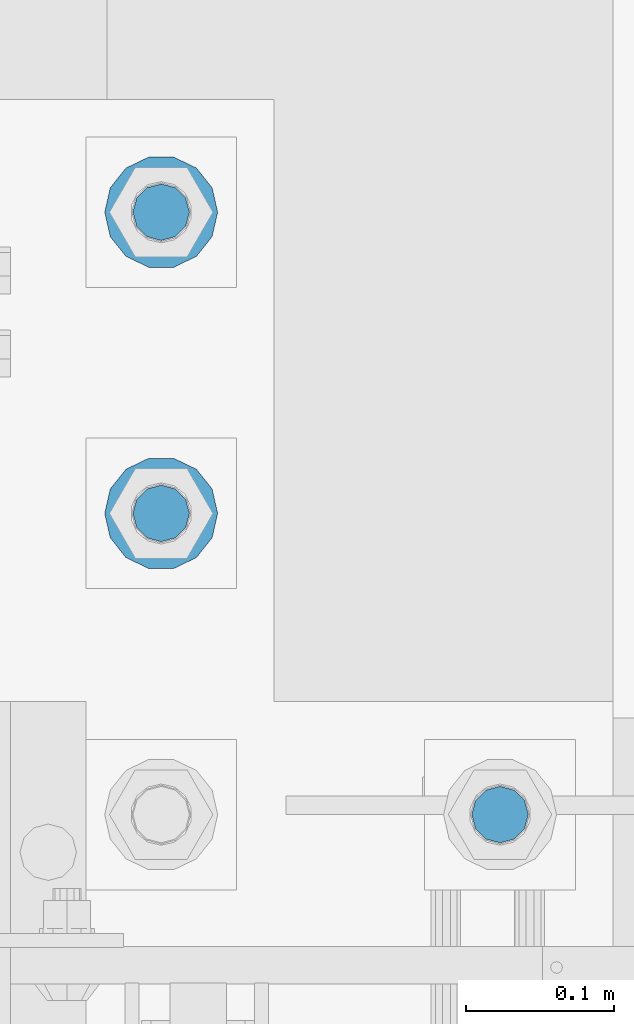
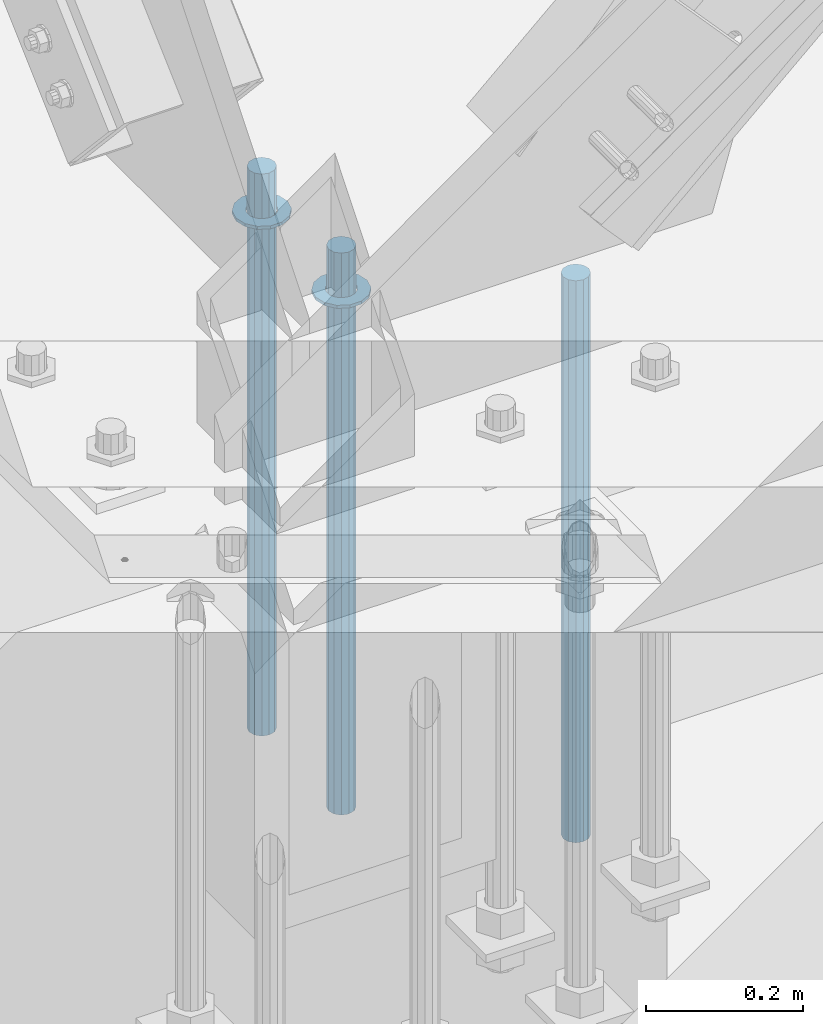
# One storey, part 920 of 1763: 5 columns, 1 element without a shape of its own.
"""IFC2X3 building model written with IfcOpenShell, lengths in millimetres."""

from ifc_helpers import new_model, si_unit, frame, origin_with_axes, place, context, subcontext, project, spatial, faceted_brep, material, type_object, element, aggregate, save


model = new_model("IFC2X3")

# Units and contexts
model_context = context("Model", 3, precision=1e-05, world=origin_with_axes())
body_context = subcontext(model_context, "Body", "Model", "MODEL_VIEW")
ifc_project = project(units=[si_unit("LENGTHUNIT", "METRE", prefix="MILLI"), si_unit("AREAUNIT", "SQUARE_METRE"), si_unit("VOLUMEUNIT", "CUBIC_METRE"), si_unit("MASSUNIT", "GRAM", prefix="KILO"), si_unit("TIMEUNIT", "SECOND"), si_unit("PLANEANGLEUNIT", "RADIAN"), si_unit("SOLIDANGLEUNIT", "STERADIAN"), si_unit("THERMODYNAMICTEMPERATUREUNIT", "DEGREE_CELSIUS"), si_unit("LUMINOUSINTENSITYUNIT", "LUMEN")], contexts=[model_context])

# Site, building, storey
site_placement = place(None, origin_with_axes())
site = spatial("IfcSite", under=ifc_project, at=site_placement, CompositionType="ELEMENT")
building_placement = place(site_placement, origin_with_axes())
building = spatial("IfcBuilding", under=site, at=building_placement, Name="Undefined", CompositionType="ELEMENT")
storey_placement = place(building_placement, origin_with_axes())
storey = spatial("IfcBuildingStorey", under=building, at=storey_placement, Name="Undefined", CompositionType="ELEMENT", Elevation=0.0)

# Assembly, columns
assembly_placement = place(storey_placement, origin_with_axes())
assembly = element("IfcElementAssembly", 1, at=assembly_placement, inside=storey, Name="TEMPLATE", AssemblyPlace="NOTDEFINED", PredefinedType="RIGID_FRAME")
ifc_material_1 = material(Name="STEEL/F436")
column_type_1 = type_object("IfcColumnType", Name="1-1/2_WASHER", PredefinedType="NOTDEFINED")
column_1_placement = place(assembly_placement, frame((-87146.8372736983, -13411.2, 5151.43750000001), z_axis=(0.0, 1.0, 0.0), x_axis=(0.0, 0.0, -1.0)))
column_1 = element("IfcColumn", 2, at=column_1_placement, type_object=column_type_1, material=ifc_material_1, Name="WASHER", ObjectType="1-1/2_WASHER", context=body_context, shape_type="Brep", body=[
    faceted_brep([(0.0, -38.0999984741211, 0.0), (0.0, -34.3269124923099, -16.5309697983248), (4.76249999999982, -34.3269124923099, -16.5309697983248), (4.76249999999982, -38.0999984741211, 0.0), (0.0, -23.7549604994492, -29.7877782890519), (4.76249999999982, -23.7549604994492, -29.7877782890519), (0.0, -8.47804724419257, -37.1447519665053), (4.76249999999982, -8.47804724419257, -37.1447519665053), (0.0, 8.47804724419257, -37.1447519665053), (4.76249999999982, 8.47804724419257, -37.1447519665053), (0.0, 23.7549604994492, -29.7877782890519), (4.76249999999982, 23.7549604994492, -29.7877782890519), (0.0, 34.3269124923099, -16.5309697983248), (4.76249999999982, 34.3269124923099, -16.5309697983248), (0.0, 38.0999984741211, 0.0), (4.76249999999982, 38.0999984741211, 0.0), (0.0, 34.3269124923099, 16.5309697983248), (4.76249999999982, 34.3269124923099, 16.5309697983248), (0.0, 23.7549604994492, 29.7877782890519), (4.76249999999982, 23.7549604994492, 29.7877782890519), (0.0, 8.47804724419257, 37.1447519665053), (4.76249999999982, 8.47804724419257, 37.1447519665053), (0.0, -8.47804724419257, 37.1447519665053), (4.76249999999982, -8.47804724419257, 37.1447519665053), (0.0, -23.7549604994492, 29.7877782890519), (4.76249999999982, -23.7549604994492, 29.7877782890519), (0.0, -34.3269124923099, 16.5309697983248), (4.76249999999982, -34.3269124923099, 16.5309697983248), (0.0, 0.0, 20.6399993896484), (0.0, 8.95536011056538, 18.5959968835978), (4.76249999999982, 8.95536011056538, 18.5959968835978), (4.76249999999982, 0.0, 20.6399993896484), (0.0, 16.1370013209453, 12.8688291298167), (4.76249999999982, 16.1370013209453, 12.8688291298167), (0.0, 20.1225115123816, 4.59283194104137), (4.76249999999982, 20.1225115123816, 4.59283194104137), (0.0, 20.1225115123816, -4.59283194104319), (4.76249999999982, 20.1225115123816, -4.59283194104319), (0.0, 16.1370013209453, -12.8688291298167), (4.76249999999982, 16.1370013209453, -12.8688291298167), (0.0, 8.95536011056538, -18.5959968835978), (4.76249999999982, 8.95536011056538, -18.5959968835978), (0.0, 0.0, -20.6399993896484), (4.76249999999982, 0.0, -20.6399993896484), (0.0, -8.95536011056538, -18.5959968835978), (4.76249999999982, -8.95536011056538, -18.5959968835978), (0.0, -16.1370013209453, -12.8688291298167), (4.76249999999982, -16.1370013209453, -12.8688291298167), (0.0, -20.1225115123816, -4.59283194104137), (4.76249999999982, -20.1225115123816, -4.59283194104137), (0.0, -20.1225115123816, 4.59283194104319), (4.76249999999982, -20.1225115123816, 4.59283194104319), (0.0, -16.1370013209453, 12.8688291298167), (4.76249999999982, -16.1370013209453, 12.8688291298167), (0.0, -8.95536011056538, 18.5959968835978), (4.76249999999982, -8.95536011056538, 18.5959968835978)], [[[0, 1, 2, 3]], [[1, 4, 5, 2]], [[4, 6, 7, 5]], [[6, 8, 9, 7]], [[8, 10, 11, 9]], [[10, 12, 13, 11]], [[12, 14, 15, 13]], [[14, 16, 17, 15]], [[16, 18, 19, 17]], [[18, 20, 21, 19]], [[20, 22, 23, 21]], [[22, 24, 25, 23]], [[24, 26, 27, 25]], [[26, 0, 3, 27]], [[28, 29, 30, 31]], [[29, 32, 33, 30]], [[32, 34, 35, 33]], [[34, 36, 37, 35]], [[36, 38, 39, 37]], [[38, 40, 41, 39]], [[40, 42, 43, 41]], [[42, 44, 45, 43]], [[44, 46, 47, 45]], [[46, 48, 49, 47]], [[48, 50, 51, 49]], [[50, 52, 53, 51]], [[52, 54, 55, 53]], [[54, 28, 31, 55]], [[5, 7, 9, 11, 13, 15, 17, 19, 21, 23, 25, 27, 3, 2], [33, 35, 37, 39, 41, 43, 45, 47, 49, 51, 53, 55, 31, 30]], [[26, 24, 22, 20, 18, 16, 14, 12, 10, 8, 6, 4, 1, 0], [54, 52, 50, 48, 46, 44, 42, 40, 38, 36, 34, 32, 29, 28]]]),
])
column_2_placement = place(assembly_placement, frame((-87146.8372736983, -13208.0, 5151.43750000001), z_axis=(0.0, 1.0, 0.0), x_axis=(0.0, 0.0, -1.0)))
column_2 = element("IfcColumn", 3, at=column_2_placement, type_object=column_type_1, material=ifc_material_1, Name="WASHER", ObjectType="1-1/2_WASHER", context=body_context, shape_type="Brep", body=[
    faceted_brep([(0.0, -38.0999984741211, 0.0), (0.0, -34.3269124923099, -16.5309697983248), (4.76249999999982, -34.3269124923099, -16.5309697983248), (4.76249999999982, -38.0999984741211, 0.0), (0.0, -23.7549604994492, -29.7877782890519), (4.76249999999982, -23.7549604994492, -29.7877782890519), (0.0, -8.47804724419257, -37.1447519665053), (4.76249999999982, -8.47804724419257, -37.1447519665053), (0.0, 8.47804724419257, -37.1447519665053), (4.76249999999982, 8.47804724419257, -37.1447519665053), (0.0, 23.7549604994492, -29.7877782890519), (4.76249999999982, 23.7549604994492, -29.7877782890519), (0.0, 34.3269124923099, -16.5309697983248), (4.76249999999982, 34.3269124923099, -16.5309697983248), (0.0, 38.0999984741211, 0.0), (4.76249999999982, 38.0999984741211, 0.0), (0.0, 34.3269124923099, 16.5309697983248), (4.76249999999982, 34.3269124923099, 16.5309697983248), (0.0, 23.7549604994492, 29.7877782890519), (4.76249999999982, 23.7549604994492, 29.7877782890519), (0.0, 8.47804724419257, 37.1447519665053), (4.76249999999982, 8.47804724419257, 37.1447519665053), (0.0, -8.47804724419257, 37.1447519665053), (4.76249999999982, -8.47804724419257, 37.1447519665053), (0.0, -23.7549604994492, 29.7877782890519), (4.76249999999982, -23.7549604994492, 29.7877782890519), (0.0, -34.3269124923099, 16.5309697983248), (4.76249999999982, -34.3269124923099, 16.5309697983248), (0.0, 0.0, 20.6399993896484), (0.0, 8.95536011056538, 18.5959968835978), (4.76249999999982, 8.95536011056538, 18.5959968835978), (4.76249999999982, 0.0, 20.6399993896484), (0.0, 16.1370013209453, 12.8688291298167), (4.76249999999982, 16.1370013209453, 12.8688291298167), (0.0, 20.1225115123816, 4.59283194104137), (4.76249999999982, 20.1225115123816, 4.59283194104137), (0.0, 20.1225115123816, -4.59283194104319), (4.76249999999982, 20.1225115123816, -4.59283194104319), (0.0, 16.1370013209453, -12.8688291298167), (4.76249999999982, 16.1370013209453, -12.8688291298167), (0.0, 8.95536011056538, -18.5959968835978), (4.76249999999982, 8.95536011056538, -18.5959968835978), (0.0, 0.0, -20.6399993896484), (4.76249999999982, 0.0, -20.6399993896484), (0.0, -8.95536011056538, -18.5959968835978), (4.76249999999982, -8.95536011056538, -18.5959968835978), (0.0, -16.1370013209453, -12.8688291298167), (4.76249999999982, -16.1370013209453, -12.8688291298167), (0.0, -20.1225115123816, -4.59283194104137), (4.76249999999982, -20.1225115123816, -4.59283194104137), (0.0, -20.1225115123816, 4.59283194104319), (4.76249999999982, -20.1225115123816, 4.59283194104319), (0.0, -16.1370013209453, 12.8688291298167), (4.76249999999982, -16.1370013209453, 12.8688291298167), (0.0, -8.95536011056538, 18.5959968835978), (4.76249999999982, -8.95536011056538, 18.5959968835978)], [[[0, 1, 2, 3]], [[1, 4, 5, 2]], [[4, 6, 7, 5]], [[6, 8, 9, 7]], [[8, 10, 11, 9]], [[10, 12, 13, 11]], [[12, 14, 15, 13]], [[14, 16, 17, 15]], [[16, 18, 19, 17]], [[18, 20, 21, 19]], [[20, 22, 23, 21]], [[22, 24, 25, 23]], [[24, 26, 27, 25]], [[26, 0, 3, 27]], [[28, 29, 30, 31]], [[29, 32, 33, 30]], [[32, 34, 35, 33]], [[34, 36, 37, 35]], [[36, 38, 39, 37]], [[38, 40, 41, 39]], [[40, 42, 43, 41]], [[42, 44, 45, 43]], [[44, 46, 47, 45]], [[46, 48, 49, 47]], [[48, 50, 51, 49]], [[50, 52, 53, 51]], [[52, 54, 55, 53]], [[54, 28, 31, 55]], [[5, 7, 9, 11, 13, 15, 17, 19, 21, 23, 25, 27, 3, 2], [33, 35, 37, 39, 41, 43, 45, 47, 49, 51, 53, 55, 31, 30]], [[26, 24, 22, 20, 18, 16, 14, 12, 10, 8, 6, 4, 1, 0], [54, 52, 50, 48, 46, 44, 42, 40, 38, 36, 34, 32, 29, 28]]]),
])
ifc_material_2 = material(Name="STEEL/F1554-GR.55")
column_type_2 = type_object("IfcColumnType", PredefinedType="NOTDEFINED")
column_3_placement = place(assembly_placement, frame((-86918.2372736983, -13614.4, 5219.70000000001), z_axis=(0.0, 1.0, 0.0), x_axis=(0.0, 0.0, -1.0)))
column_3 = element("IfcColumn", 4, at=column_3_placement, type_object=column_type_2, material=ifc_material_2, Name="ALL THREADED ROD", context=body_context, shape_type="Brep", body=[
    faceted_brep([(0.0, -19.0500000000029, 0.0), (0.0, -16.4977839420899, -9.52500000000146), (876.299, -16.4977839420899, -9.52499999999964), (876.299, -19.0500000000029, 0.0), (0.0, -9.52499999999418, -16.4977839420935), (876.299, -9.52499999999418, -16.4977839420935), (1.45519152283669e-11, 1.81898940354586e-12, -19.0499999999993), (876.299, 0.0, -19.0500000000002), (0.0, 9.52499999999418, -16.4977839420935), (876.299, 9.52499999999418, -16.4977839420935), (0.0, 16.4977839420899, -9.52500000000146), (876.299, 16.4977839420899, -9.52499999999964), (0.0, 19.0500000000029, 0.0), (876.299, 19.0500000000029, 0.0), (0.0, 16.4977839420899, 9.52500000000146), (876.299, 16.4977839420899, 9.52499999999964), (0.0, 9.52499999999418, 16.4977839420935), (876.299, 9.52499999999418, 16.4977839420935), (1.45519152283669e-11, 1.81898940354586e-12, 19.0499999999993), (876.299, 0.0, 19.0500000000002), (0.0, -9.52499999999418, 16.4977839420935), (876.299, -9.52499999999418, 16.4977839420935), (0.0, -16.4977839420899, 9.52500000000146), (876.299, -16.4977839420899, 9.52499999999964)], [[[0, 1, 2, 3]], [[1, 4, 5, 2]], [[4, 6, 7, 5]], [[6, 8, 9, 7]], [[8, 10, 11, 9]], [[10, 12, 13, 11]], [[12, 14, 15, 13]], [[14, 16, 17, 15]], [[16, 18, 19, 17]], [[18, 20, 21, 19]], [[20, 22, 23, 21]], [[22, 0, 3, 23]], [[5, 7, 9, 11, 13, 15, 17, 19, 21, 23, 3, 2]], [[22, 20, 18, 16, 14, 12, 10, 8, 6, 4, 1, 0]]]),
])
column_4_placement = place(assembly_placement, frame((-87146.8372736983, -13411.2, 5219.70000000001), z_axis=(0.0, 1.0, 0.0), x_axis=(0.0, 0.0, -1.0)))
column_4 = element("IfcColumn", 5, at=column_4_placement, type_object=column_type_2, material=ifc_material_2, Name="ALL THREADED ROD", context=body_context, shape_type="Brep", body=[
    faceted_brep([(0.0, -19.0500000000029, 0.0), (0.0, -16.4977839420899, -9.52500000000146), (876.299, -16.4977839420899, -9.52499999999964), (876.299, -19.0500000000029, 0.0), (0.0, -9.52499999999418, -16.4977839420935), (876.299, -9.52499999999418, -16.4977839420935), (1.45519152283669e-11, 1.81898940354586e-12, -19.0499999999993), (876.299, 0.0, -19.0500000000002), (0.0, 9.52499999999418, -16.4977839420935), (876.299, 9.52499999999418, -16.4977839420935), (0.0, 16.4977839420899, -9.52500000000146), (876.299, 16.4977839420899, -9.52499999999964), (0.0, 19.0500000000029, 0.0), (876.299, 19.0500000000029, 0.0), (0.0, 16.4977839420899, 9.52500000000146), (876.299, 16.4977839420899, 9.52499999999964), (0.0, 9.52499999999418, 16.4977839420935), (876.299, 9.52499999999418, 16.4977839420935), (1.45519152283669e-11, 1.81898940354586e-12, 19.0499999999993), (876.299, 0.0, 19.0500000000002), (0.0, -9.52499999999418, 16.4977839420935), (876.299, -9.52499999999418, 16.4977839420935), (0.0, -16.4977839420899, 9.52500000000146), (876.299, -16.4977839420899, 9.52499999999964)], [[[0, 1, 2, 3]], [[1, 4, 5, 2]], [[4, 6, 7, 5]], [[6, 8, 9, 7]], [[8, 10, 11, 9]], [[10, 12, 13, 11]], [[12, 14, 15, 13]], [[14, 16, 17, 15]], [[16, 18, 19, 17]], [[18, 20, 21, 19]], [[20, 22, 23, 21]], [[22, 0, 3, 23]], [[5, 7, 9, 11, 13, 15, 17, 19, 21, 23, 3, 2]], [[22, 20, 18, 16, 14, 12, 10, 8, 6, 4, 1, 0]]]),
])
column_5_placement = place(assembly_placement, frame((-87146.8372736983, -13208.0, 5219.70000000001), z_axis=(0.0, 1.0, 0.0), x_axis=(0.0, 0.0, -1.0)))
column_5 = element("IfcColumn", 6, at=column_5_placement, type_object=column_type_2, material=ifc_material_2, Name="ALL THREADED ROD", context=body_context, shape_type="Brep", body=[
    faceted_brep([(0.0, -19.0500000000029, 0.0), (0.0, -16.4977839420899, -9.52500000000146), (876.299, -16.4977839420899, -9.52499999999964), (876.299, -19.0500000000029, 0.0), (0.0, -9.52499999999418, -16.4977839420935), (876.299, -9.52499999999418, -16.4977839420935), (1.45519152283669e-11, 1.81898940354586e-12, -19.0499999999993), (876.299, 0.0, -19.0500000000002), (0.0, 9.52499999999418, -16.4977839420935), (876.299, 9.52499999999418, -16.4977839420935), (0.0, 16.4977839420899, -9.52500000000146), (876.299, 16.4977839420899, -9.52499999999964), (0.0, 19.0500000000029, 0.0), (876.299, 19.0500000000029, 0.0), (0.0, 16.4977839420899, 9.52500000000146), (876.299, 16.4977839420899, 9.52499999999964), (0.0, 9.52499999999418, 16.4977839420935), (876.299, 9.52499999999418, 16.4977839420935), (1.45519152283669e-11, 1.81898940354586e-12, 19.0499999999993), (876.299, 0.0, 19.0500000000002), (0.0, -9.52499999999418, 16.4977839420935), (876.299, -9.52499999999418, 16.4977839420935), (0.0, -16.4977839420899, 9.52500000000146), (876.299, -16.4977839420899, 9.52499999999964)], [[[0, 1, 2, 3]], [[1, 4, 5, 2]], [[4, 6, 7, 5]], [[6, 8, 9, 7]], [[8, 10, 11, 9]], [[10, 12, 13, 11]], [[12, 14, 15, 13]], [[14, 16, 17, 15]], [[16, 18, 19, 17]], [[18, 20, 21, 19]], [[20, 22, 23, 21]], [[22, 0, 3, 23]], [[5, 7, 9, 11, 13, 15, 17, 19, 21, 23, 3, 2]], [[22, 20, 18, 16, 14, 12, 10, 8, 6, 4, 1, 0]]]),
])
aggregate(assembly, [column_3, column_1, column_4, column_2, column_5])

save(model, "model.ifc")
